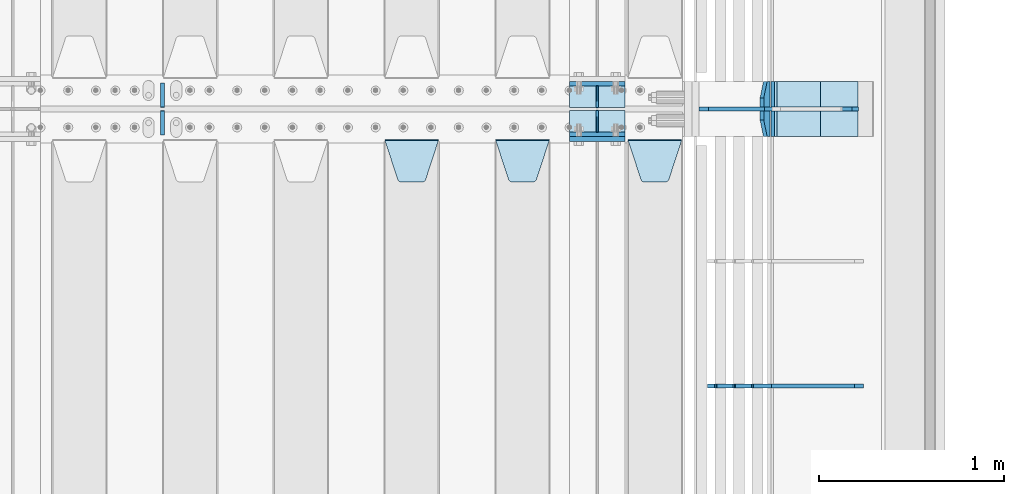
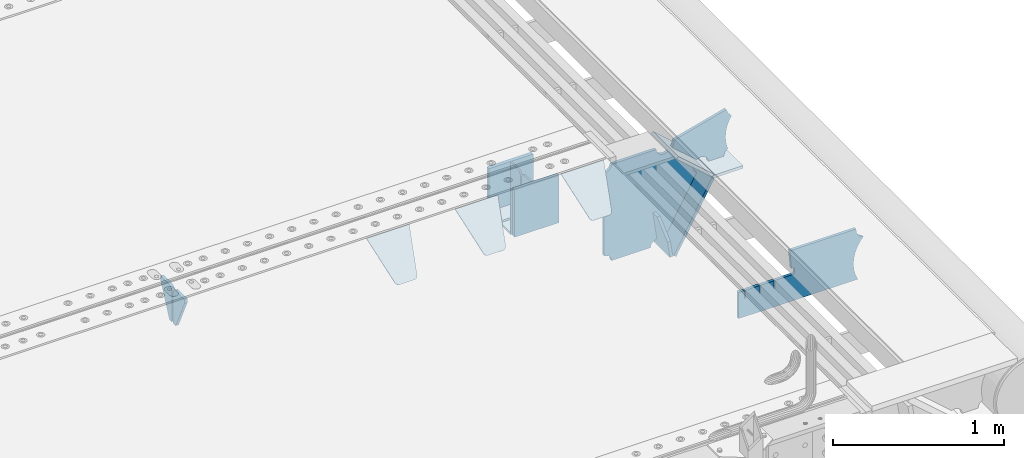
# One storey, part 186 of 219: 19 plates.
"""IFC2X3 building model written with IfcOpenShell, lengths in millimetres."""

from ifc_helpers import new_model, si_unit, frame, origin_with_axes, place, context, subcontext, project, spatial, faceted_brep, material, type_object, element, save


model = new_model("IFC2X3")

# Units and contexts
model_context = context("Model", 3, precision=1e-05, world=origin_with_axes())
body_context = subcontext(model_context, "Body", "Model", "MODEL_VIEW")
ifc_project = project(units=[si_unit("LENGTHUNIT", "METRE", prefix="MILLI"), si_unit("AREAUNIT", "SQUARE_METRE"), si_unit("VOLUMEUNIT", "CUBIC_METRE"), si_unit("MASSUNIT", "GRAM", prefix="KILO"), si_unit("TIMEUNIT", "SECOND"), si_unit("PLANEANGLEUNIT", "RADIAN"), si_unit("SOLIDANGLEUNIT", "STERADIAN"), si_unit("THERMODYNAMICTEMPERATUREUNIT", "DEGREE_CELSIUS"), si_unit("LUMINOUSINTENSITYUNIT", "LUMEN")], contexts=[model_context])

# Site, building, storey
site_placement = place(None, origin_with_axes())
site = spatial("IfcSite", under=ifc_project, at=site_placement, CompositionType="ELEMENT")
building_placement = place(site_placement, origin_with_axes())
building = spatial("IfcBuilding", under=site, at=building_placement, Name="Standard", CompositionType="ELEMENT")
storey_placement = place(building_placement, origin_with_axes())
storey = spatial("IfcBuildingStorey", under=building, at=storey_placement, Name="Undefined", CompositionType="ELEMENT", Elevation=0.0)

# Plates
ifc_material = material(Name="STEEL/S355N")
plate_type_1 = type_object("IfcPlateType", PredefinedType="NOTDEFINED")
for number, where, z_axis, x_axis in (
    (1, (13405.0, 27137.5, -339.999999999995), (0.0, 0.0, 1.0), (1.0, 0.0, 0.0)),
    (2, (13405.0, 26862.5, -339.999999999995), (0.0, 0.0, 1.0), (1.0, 0.0, 0.0)),
):
    element("IfcPlate", number, at=place(storey_placement, frame(where, z_axis=z_axis, x_axis=x_axis)), inside=storey, type_object=plate_type_1, material=ifc_material, context=body_context, shape_type="Brep", body=[
        faceted_brep([(0.0, -12.5, 0.0), (0.0, -12.5, 310.0), (0.0, 12.5, 310.0), (0.0, 12.5, 0.0), (300.0, -12.5, 310.0), (300.0, 12.5, 310.0), (300.0, -12.5, 0.0), (300.0, 12.5, 0.0)], [[[0, 1, 2, 3]], [[1, 4, 5, 2]], [[4, 6, 7, 5]], [[6, 0, 3, 7]], [[5, 7, 3, 2]], [[6, 4, 1, 0]]]),
    ])
plate_1_placement = place(storey_placement, frame((13405.0, 26837.5, -340.000000000044), z_axis=(0.0, 0.0, 1.0), x_axis=(1.0, 0.0, 0.0)))
element("IfcPlate", 3, at=plate_1_placement, inside=storey, type_object=plate_type_1, material=ifc_material, context=body_context, shape_type="Brep", body=[
    faceted_brep([(0.0, -12.5, 0.0), (9.27684595808387e-10, -12.5, 340.0), (9.27684595808387e-10, 12.5, 340.0), (0.0, 12.5, 0.0), (300.0, -12.5, 340.0), (300.0, 12.5, 340.0), (300.0, -12.5, 0.0), (300.0, 12.5, 0.0)], [[[0, 1, 2, 3]], [[1, 4, 5, 2]], [[4, 6, 7, 5]], [[6, 0, 3, 7]], [[5, 7, 3, 2]], [[6, 4, 1, 0]]]),
])
plate_type_2 = type_object("IfcPlateType", PredefinedType="NOTDEFINED")
for number, where, z_axis, x_axis in (
    (4, (13405.0, 27008.0, -342.999999999995), (0.0, 1.0, 0.0), (1.0, 0.0, 0.0)),
    (5, (13405.0, 26992.0, -342.999999999995), (0.0, -1.0, 0.0), (1.0, 0.0, 0.0)),
):
    element("IfcPlate", number, at=place(storey_placement, frame(where, z_axis=z_axis, x_axis=x_axis)), inside=storey, type_object=plate_type_2, material=ifc_material, context=body_context, shape_type="Brep", body=[
        faceted_brep([(0.0, -7.0, 0.0), (0.0, -7.0, 117.0), (0.0, 7.0, 117.0), (0.0, 7.0, 0.0), (300.0, -7.0, 117.0), (300.0, 7.0, 117.0), (300.0, -7.0, 0.0), (300.0, 7.0, 0.0)], [[[0, 1, 2, 3]], [[1, 4, 5, 2]], [[4, 6, 7, 5]], [[6, 0, 3, 7]], [[5, 7, 3, 2]], [[6, 4, 1, 0]]]),
    ])
plate_type_3 = type_object("IfcPlateType", PredefinedType="NOTDEFINED")
for number, where, z_axis, x_axis in (
    (6, (13555.0, 27008.0, -29.9999999999945), (0.0, 0.0, -1.0), (0.0, 1.0, 0.0)),
    (7, (13555.0, 26992.0, -29.9999999999945), (0.0, 0.0, -1.0), (0.0, -1.0, 0.0)),
):
    element("IfcPlate", number, at=place(storey_placement, frame(where, z_axis=z_axis, x_axis=x_axis)), inside=storey, type_object=plate_type_3, material=ifc_material, context=body_context, shape_type="Brep", body=[
        faceted_brep([(0.0, -5.0, 30.0), (0.0, -5.0, 306.0), (0.0, 5.0, 306.0), (0.0, 5.0, 30.0), (117.0, -5.0, 306.0), (117.0, 5.0, 306.0), (117.0, -5.0, 0.0), (117.0, 5.0, 0.0), (30.0, -5.0, 0.0), (30.0, 5.0, 0.0), (24.7905546699913, -5.0, 0.455767409633758), (24.7905546699913, 5.0, 0.455767409633758), (19.7393957002278, -5.0, 1.80922137642275), (19.7393957002278, 5.0, 1.80922137642275), (15.0, -5.0, 4.01923788646684), (15.0, 5.0, 4.01923788646684), (10.7163717094008, -5.0, 7.01866670643066), (10.7163717094008, 5.0, 7.01866670643066), (7.01866670643358, -5.0, 10.7163717094038), (7.01866670643358, 5.0, 10.7163717094038), (4.01923788646673, -5.0, 15.0), (4.01923788646673, 5.0, 15.0), (1.80922137642483, -5.0, 19.7393957002299), (1.80922137642483, 5.0, 19.7393957002299), (0.455767409635882, -5.0, 24.7905546699921), (0.455767409635882, 5.0, 24.7905546699921)], [[[0, 1, 2, 3]], [[1, 4, 5, 2]], [[4, 6, 7, 5]], [[6, 8, 9, 7]], [[8, 10, 11, 9]], [[10, 12, 13, 11]], [[12, 14, 15, 13]], [[14, 16, 17, 15]], [[16, 18, 19, 17]], [[18, 20, 21, 19]], [[20, 22, 23, 21]], [[22, 24, 25, 23]], [[24, 0, 3, 25]], [[5, 7, 9, 11, 13, 15, 17, 19, 21, 23, 25, 3, 2]], [[24, 22, 20, 18, 16, 14, 12, 10, 8, 6, 4, 1, 0]]]),
    ])
plate_type_4 = type_object("IfcPlateType", PredefinedType="NOTDEFINED")
plate_2_placement = place(storey_placement, frame((13722.0, 26831.767766956, -1.76776695296758), z_axis=(0.0, -0.707106781186547, -0.707106781186548), x_axis=(1.0, 0.0, 0.0)))
element("IfcPlate", 8, at=plate_2_placement, inside=storey, type_object=plate_type_4, material=ifc_material, context=body_context, shape_type="Brep", body=[
    faceted_brep([(0.0, -2.5, 0.0), (69.345504679477, -2.5, 300.171731424834), (69.345504679477, 2.49999999999636, 300.171731424831), (0.0, 2.5, 0.0), (70.9274061199576, -2.50000000000364, 304.8974424154), (70.9274061199576, 2.49999999999636, 304.8974424154), (73.3818627772307, -2.50000000000364, 309.234538108532), (73.3818627772307, 2.49999999999636, 309.234538108532), (76.6187032999569, -2.50000000000364, 313.023683126106), (76.6187032999569, 2.49999999999636, 313.023683126106), (80.5190132704993, -2.50000000000364, 316.125672595372), (80.5190132704993, 2.49999999999636, 316.125672595372), (84.9395038596831, -2.50000000000364, 318.426546230476), (84.9395038596831, 2.5, 318.426546230479), (89.7177759439237, -2.50000000000364, 319.841774983277), (89.7177759439237, 2.5, 319.841774983281), (94.6782862926502, -2.50000000000364, 320.319366455078), (94.6782862926502, 2.49999999999636, 320.319366455078), (195.32171370735, -2.50000000000364, 320.319366455078), (195.32171370735, 2.49999999999636, 320.319366455078), (200.282224056076, -2.50000000000364, 319.841774983277), (200.282224056076, 2.5, 319.841774983281), (205.060496140317, -2.50000000000364, 318.426546230476), (205.060496140317, 2.49999999999636, 318.426546230476), (209.480986729501, -2.50000000000364, 316.125672595372), (209.480986729501, 2.49999999999636, 316.125672595372), (213.381296700043, -2.50000000000364, 313.023683126106), (213.381296700043, 2.49999999999272, 313.023683126106), (216.618137222769, -2.50000000000364, 309.234538108529), (216.618137222769, 2.49999999999636, 309.234538108525), (219.072593880042, -2.50000000000364, 304.8974424154), (219.072593880042, 2.49999999999636, 304.8974424154), (220.654495320523, -2.5, 300.171731424834), (220.654495320523, 2.49999999999636, 300.171731424831), (290.0, -2.50000000000364, 3.63797880709171e-12), (290.0, 2.49999999999636, 0.0)], [[[0, 1, 2, 3]], [[1, 4, 5, 2]], [[4, 6, 7, 5]], [[6, 8, 9, 7]], [[8, 10, 11, 9]], [[10, 12, 13, 11]], [[12, 14, 15, 13]], [[14, 16, 17, 15]], [[16, 18, 19, 17]], [[18, 20, 21, 19]], [[20, 22, 23, 21]], [[22, 24, 25, 23]], [[24, 26, 27, 25]], [[26, 28, 29, 27]], [[28, 30, 31, 29]], [[30, 32, 33, 31]], [[32, 34, 35, 33]], [[34, 0, 3, 35]], [[5, 7, 9, 11, 13, 15, 17, 19, 21, 23, 25, 27, 29, 31, 33, 35, 3, 2]], [[34, 32, 30, 28, 26, 24, 22, 20, 18, 16, 14, 12, 10, 8, 6, 4, 1, 0]]]),
])
plate_3_placement = place(storey_placement, frame((13005.0, 26831.767766956, -1.76776695296758), z_axis=(0.0, -0.707106781186547, -0.707106781186548), x_axis=(1.0, 0.0, 0.0)))
element("IfcPlate", 9, at=plate_3_placement, inside=storey, type_object=plate_type_4, material=ifc_material, context=body_context, shape_type="Brep", body=[
    faceted_brep([(0.0, -2.5, 0.0), (69.345504679477, -2.5, 300.171731424834), (69.345504679477, 2.49999999999636, 300.171731424831), (0.0, 2.5, 0.0), (70.9274061199576, -2.50000000000364, 304.8974424154), (70.9274061199576, 2.49999999999636, 304.8974424154), (73.3818627772307, -2.50000000000364, 309.234538108532), (73.3818627772307, 2.49999999999636, 309.234538108532), (76.6187032999569, -2.50000000000364, 313.023683126106), (76.6187032999569, 2.49999999999636, 313.023683126106), (80.5190132704993, -2.50000000000364, 316.125672595372), (80.5190132704993, 2.49999999999636, 316.125672595372), (84.9395038596831, -2.50000000000364, 318.426546230476), (84.9395038596831, 2.5, 318.426546230479), (89.7177759439237, -2.50000000000364, 319.841774983277), (89.7177759439237, 2.5, 319.841774983281), (94.6782862926502, -2.50000000000364, 320.319366455078), (94.6782862926502, 2.49999999999636, 320.319366455078), (195.32171370735, -2.50000000000364, 320.319366455078), (195.32171370735, 2.49999999999636, 320.319366455078), (200.282224056076, -2.50000000000364, 319.841774983277), (200.282224056076, 2.5, 319.841774983281), (205.060496140317, -2.50000000000364, 318.426546230476), (205.060496140317, 2.49999999999636, 318.426546230476), (209.480986729501, -2.50000000000364, 316.125672595372), (209.480986729501, 2.49999999999636, 316.125672595372), (213.381296700043, -2.50000000000364, 313.023683126106), (213.381296700043, 2.49999999999272, 313.023683126106), (216.618137222769, -2.50000000000364, 309.234538108529), (216.618137222769, 2.49999999999636, 309.234538108525), (219.072593880042, -2.50000000000364, 304.8974424154), (219.072593880042, 2.49999999999636, 304.8974424154), (220.654495320523, -2.5, 300.171731424834), (220.654495320523, 2.49999999999636, 300.171731424831), (290.0, -2.50000000000364, 3.63797880709171e-12), (290.0, 2.49999999999636, 0.0)], [[[0, 1, 2, 3]], [[1, 4, 5, 2]], [[4, 6, 7, 5]], [[6, 8, 9, 7]], [[8, 10, 11, 9]], [[10, 12, 13, 11]], [[12, 14, 15, 13]], [[14, 16, 17, 15]], [[16, 18, 19, 17]], [[18, 20, 21, 19]], [[20, 22, 23, 21]], [[22, 24, 25, 23]], [[24, 26, 27, 25]], [[26, 28, 29, 27]], [[28, 30, 31, 29]], [[30, 32, 33, 31]], [[32, 34, 35, 33]], [[34, 0, 3, 35]], [[5, 7, 9, 11, 13, 15, 17, 19, 21, 23, 25, 27, 29, 31, 33, 35, 3, 2]], [[34, 32, 30, 28, 26, 24, 22, 20, 18, 16, 14, 12, 10, 8, 6, 4, 1, 0]]]),
])
plate_4_placement = place(storey_placement, frame((12405.0, 26831.767766956, -1.76776695296758), z_axis=(0.0, -0.707106781186547, -0.707106781186548), x_axis=(1.0, 0.0, 0.0)))
element("IfcPlate", 10, at=plate_4_placement, inside=storey, type_object=plate_type_4, material=ifc_material, context=body_context, shape_type="Brep", body=[
    faceted_brep([(0.0, -2.5, 0.0), (69.345504679477, -2.5, 300.171731424834), (69.345504679477, 2.49999999999636, 300.171731424831), (0.0, 2.5, 0.0), (70.9274061199576, -2.50000000000364, 304.8974424154), (70.9274061199576, 2.49999999999636, 304.8974424154), (73.3818627772307, -2.50000000000364, 309.234538108532), (73.3818627772307, 2.49999999999636, 309.234538108532), (76.6187032999569, -2.50000000000364, 313.023683126106), (76.6187032999569, 2.49999999999636, 313.023683126106), (80.5190132704993, -2.50000000000364, 316.125672595372), (80.5190132704993, 2.49999999999636, 316.125672595372), (84.9395038596831, -2.50000000000364, 318.426546230476), (84.9395038596831, 2.5, 318.426546230479), (89.7177759439237, -2.50000000000364, 319.841774983277), (89.7177759439237, 2.5, 319.841774983281), (94.6782862926502, -2.50000000000364, 320.319366455078), (94.6782862926502, 2.49999999999636, 320.319366455078), (195.32171370735, -2.50000000000364, 320.319366455078), (195.32171370735, 2.49999999999636, 320.319366455078), (200.282224056076, -2.50000000000364, 319.841774983277), (200.282224056076, 2.5, 319.841774983281), (205.060496140317, -2.50000000000364, 318.426546230476), (205.060496140317, 2.49999999999636, 318.426546230476), (209.480986729501, -2.50000000000364, 316.125672595372), (209.480986729501, 2.49999999999636, 316.125672595372), (213.381296700043, -2.50000000000364, 313.023683126106), (213.381296700043, 2.49999999999272, 313.023683126106), (216.618137222769, -2.50000000000364, 309.234538108529), (216.618137222769, 2.49999999999636, 309.234538108525), (219.072593880042, -2.50000000000364, 304.8974424154), (219.072593880042, 2.49999999999636, 304.8974424154), (220.654495320523, -2.5, 300.171731424834), (220.654495320523, 2.49999999999636, 300.171731424831), (290.0, -2.50000000000364, 3.63797880709171e-12), (290.0, 2.49999999999636, 0.0)], [[[0, 1, 2, 3]], [[1, 4, 5, 2]], [[4, 6, 7, 5]], [[6, 8, 9, 7]], [[8, 10, 11, 9]], [[10, 12, 13, 11]], [[12, 14, 15, 13]], [[14, 16, 17, 15]], [[16, 18, 19, 17]], [[18, 20, 21, 19]], [[20, 22, 23, 21]], [[22, 24, 25, 23]], [[24, 26, 27, 25]], [[26, 28, 29, 27]], [[28, 30, 31, 29]], [[30, 32, 33, 31]], [[32, 34, 35, 33]], [[34, 0, 3, 35]], [[5, 7, 9, 11, 13, 15, 17, 19, 21, 23, 25, 27, 29, 31, 33, 35, 3, 2]], [[34, 32, 30, 28, 26, 24, 22, 20, 18, 16, 14, 12, 10, 8, 6, 4, 1, 0]]]),
])
plate_type_5 = type_object("IfcPlateType", PredefinedType="NOTDEFINED")
plate_5_placement = place(storey_placement, frame((14481.0775331947, 27150.0000000017, -871.412303810021), z_axis=(0.0, -1.0, 0.0), x_axis=(-0.137902988002462, 0.0, 0.990445741017645)))
element("IfcPlate", 11, at=plate_5_placement, inside=storey, type_object=plate_type_5, material=ifc_material, context=body_context, shape_type="Brep", body=[
    faceted_brep([(0.0, -10.0, 0.0), (-1.97815097635612e-10, -10.0, 300.0), (-1.97815097635612e-10, 10.0000000000018, 300.0), (0.0, 10.0, 0.0), (115.0, -10.0, 300.0), (115.0, 10.0, 300.0), (250.0, -10.0, 210.0), (250.0, 10.0, 210.0), (250.0, -10.0, 90.0), (250.0, 10.0, 90.0), (115.0, -10.0, -1.09139364212751e-10), (115.0, 10.0, -1.09139364212751e-10)], [[[0, 1, 2, 3]], [[1, 4, 5, 2]], [[4, 6, 7, 5]], [[6, 8, 9, 7]], [[8, 10, 11, 9]], [[10, 0, 3, 11]], [[5, 7, 9, 11, 3, 2]], [[10, 8, 6, 4, 1, 0]]]),
])
plate_type_6 = type_object("IfcPlateType", PredefinedType="NOTDEFINED")
plate_6_placement = place(storey_placement, frame((14509.9988298914, 27000.0000000001, -179.999999999866), z_axis=(0.0, 0.0, -1.0), x_axis=(-1.0, 0.0, 0.0)))
element("IfcPlate", 12, at=plate_6_placement, inside=storey, type_object=plate_type_6, material=ifc_material, context=body_context, shape_type="Brep", body=[
    faceted_brep([(46.0258547361573, 10.0, 641.078828352488), (73.3015011074949, 10.0000000000109, 445.179898435785), (73.3015011074949, -9.99999999998545, 445.179898435785), (46.0258547361573, -10.0, 641.078828352488), (53.4925862871423, 10.0000000000109, 442.421838675736), (53.4925862871423, -9.99999999998545, 442.421838675736), (25.7820501124042, 10.0, 641.444230671291), (25.7820501124042, -10.0, 641.444230671291), (54.66525031116, 10.0, 642.447174185377), (54.66525031116, -10.0, 642.447174185377), (68.6036632070372, -10.0, 649.549150281387), (68.6036632070372, 10.0, 649.549150281387), (79.66525031116, -10.0, 660.610737385511), (79.66525031116, 10.0, 660.610737385511), (86.7672264071698, -10.0, 674.549150281387), (86.7672264071698, 10.0, 674.549150281387), (89.2144005924129, -10.0, 690.0), (89.2144005924129, 10.0, 690.0), (353.0, -10.0, 690.0), (353.0, 10.0, 690.0), (355.447174185243, -10.0, 674.549150281253), (355.447174185243, 10.0, 674.549150281253), (362.549150281253, -10.0, 660.610737385376), (362.549150281253, 10.0, 660.610737385376), (373.610737385376, -10.0, 649.549150281253), (373.610737385376, 10.0, 649.549150281253), (387.549150281253, -10.0, 642.447174185242), (387.549150281253, 10.0, 642.447174185242), (403.0, -10.0, 640.0), (403.0, 10.0, 640.0), (403.0, -10.0, 50.0), (403.0, 10.0, 50.0), (387.549150281253, -10.0, 47.5528258147577), (387.549150281253, 10.0, 47.5528258147577), (373.610737385376, -10.0, 40.4508497187474), (373.610737385376, 10.0, 40.4508497187474), (362.549150281253, -10.0, 29.3892626146236), (362.549150281253, 10.0, 29.3892626146236), (355.447174185243, -10.0, 15.4508497187474), (355.447174185243, 10.0, 15.4508497187474), (353.0, -10.0, 0.0), (353.0, 10.0, 0.0), (50.0, -10.0, 0.0), (50.0, 10.0, 0.0), (47.0349915316328, -10.0, 16.9620037619133), (47.0349915316328, 10.0, 16.9620037619133), (38.4916171352343, -10.0, 31.9123081320451), (38.4916171352343, 10.0, 31.9123081320451), (25.3831239081501, -10.0, 43.0778019479116), (25.3831239081501, 10.0, 43.0778019479116), (9.26418358741648, -10.0, 49.1342538608113), (9.26418358741648, 10.0, 49.1342538608113), (-7.95349204488593, -10.0, 49.363366622344), (-7.95349204488593, 10.0, 49.363366622344), (-24.2278808265401, -10.0, 43.7379673813837), (-24.2278808265401, 10.0, 43.7379673813837), (-37.6288347353438, -10.0, 32.9252303934259), (-37.6288347353438, 10.0, 32.9252303934259), (-210.371165264656, -10.0, 184.074769606574), (-210.371165264656, 10.0, 184.074769606574), (-202.382363280569, -10.0, 196.529747922069), (-202.382363280569, 10.0, 196.529747922069), (-198.388707244047, -10.0, 210.777489969227), (-198.388707244047, 10.0, 210.777489969227), (-198.739957464426, -10.0, 225.570193077959), (-198.739957464426, 10.0, 225.570193077959), (-203.40535180681, -10.0, 239.612327446012), (-203.40535180681, 10.0, 239.612327446012), (-211.976299808361, -10.0, 251.674097313455), (-211.976299808361, 10.0, 251.674097313455), (-223.702166612962, -10.0, 260.699145216992), (-223.702166612962, 10.0, 260.699145216992), (-9.29783338703783, -10.0, 646.300854783008), (-9.29783338703783, 10.0, 646.300854783008), (6.98069453597964, -10.0, 640.647282345602), (6.98069453597964, 10.0, 640.647282345602), (24.2117663163681, -10.0, 640.855891896051), (24.2117663163681, 10.0, 640.855891896051)], [[[0, 1, 2, 3]], [[4, 5, 2, 1]], [[6, 7, 5, 4]], [[8, 9, 10, 11]], [[11, 10, 12, 13]], [[13, 12, 14, 15]], [[15, 14, 16, 17]], [[18, 19, 17, 16]], [[18, 20, 21, 19]], [[20, 22, 23, 21]], [[22, 24, 25, 23]], [[24, 26, 27, 25]], [[26, 28, 29, 27]], [[28, 30, 31, 29]], [[30, 32, 33, 31]], [[32, 34, 35, 33]], [[34, 36, 37, 35]], [[36, 38, 39, 37]], [[38, 40, 41, 39]], [[40, 42, 43, 41]], [[42, 44, 45, 43]], [[44, 46, 47, 45]], [[46, 48, 49, 47]], [[48, 50, 51, 49]], [[50, 52, 53, 51]], [[52, 54, 55, 53]], [[54, 56, 57, 55]], [[56, 58, 59, 57]], [[58, 60, 61, 59]], [[60, 62, 63, 61]], [[62, 64, 65, 63]], [[64, 66, 67, 65]], [[66, 68, 69, 67]], [[68, 70, 71, 69]], [[70, 72, 73, 71]], [[72, 74, 75, 73]], [[74, 76, 77, 75]], [[1, 0, 8, 11, 13, 15, 17, 19, 21, 23, 25, 27, 29, 31, 33, 35, 37, 39, 41, 43, 45, 47, 49, 51, 53, 55, 57, 59, 61, 63, 65, 67, 69, 71, 73, 75, 77, 6, 4]], [[9, 8, 0, 3]], [[76, 74, 72, 70, 68, 66, 64, 62, 60, 58, 56, 54, 52, 50, 48, 46, 44, 42, 40, 38, 36, 34, 32, 30, 28, 26, 24, 22, 20, 18, 16, 14, 12, 10, 9, 3, 2, 5, 7]], [[77, 76, 7, 6]]]),
])
plate_type_7 = type_object("IfcPlateType", PredefinedType="NOTDEFINED")
plate_7_placement = place(storey_placement, frame((15050.9988502513, 26999.9999999993, -28.9999913318487), z_axis=(0.260769276985653, 0.0, -0.965401151946889), x_axis=(-0.965401151946889, 0.0, -0.260769276985654)))
element("IfcPlate", 13, at=plate_7_placement, inside=storey, type_object=plate_type_7, material=ifc_material, context=body_context, shape_type="Brep", body=[
    faceted_brep([(183.436474692322, 10.0, 275.852500330424), (184.918388609056, 10.0, 264.417843531324), (184.918388609056, -10.0, 264.417843531324), (183.436474692322, -10.0, 275.852500330424), (183.794583267612, 10.0, 224.576469334609), (183.794583267612, -10.0, 224.576469334609), (176.452049775835, 10.0, 185.401410454623), (176.452049775835, -10.0, 185.401410454623), (163.071585676769, 10.0, 147.857286855559), (163.071585676769, -10.0, 147.857286855559), (143.982662403743, 10.0, 112.868559462228), (143.982662403743, -10.0, 112.868559462228), (119.655312600249, 10.0, 81.2967668639835), (119.655312600249, -10.0, 81.2967668639835), (100.960891712748, 10.0, 63.6280409830915), (100.960891712748, -10.0, 63.6280409830915), (194.486836975902, -10.0, 278.751956446687), (207.178624553371, -10.0, 286.650994937515), (207.178624553371, 10.0, 286.650994937515), (194.486836975902, 10.0, 278.751956446687), (216.968013469443, -10.0, 297.948965801396), (216.968013469443, 10.0, 297.948965801396), (222.979925232859, -10.0, 311.635937633766), (222.979925232859, 10.0, 311.635937633766), (323.381647032762, -10.0, 284.515917834984), (323.381647032762, 10.0, 284.515917834984), (321.720617177332, -10.0, 268.853198956861), (321.720617177332, 10.0, 268.853198956861), (325.01434448114, -10.0, 253.450889283182), (325.01434448114, 10.0, 253.450889283182), (332.935986082481, -10.0, 239.837389469555), (332.935986082481, 10.0, 239.837389469555), (344.699462330087, -10.0, 229.363593146937), (344.699462330087, 10.0, 229.363593146937), (359.137460970805, -10.0, 223.068835162201), (359.137460970805, 10.0, 223.068835162201), (374.817271777683, -10.0, 221.57775639289), (374.817271777683, 10.0, 221.57775639289), (390.182952880858, -10.0, 225.038330078125), (390.182952880858, 10.0, 225.038330078125), (512.909060513028, -10.0, 41.5599003357015), (512.909060513028, 10.0, 41.5599003357015), (503.648024844581, -10.0, 33.5643666747674), (503.648024844581, 10.0, 33.5643666747674), (496.606064569702, -10.0, 23.5590612989986), (496.606064569702, 10.0, 23.5590612989986), (492.204839143929, -10.0, 12.1430832451083), (492.204839143929, 10.0, 12.1430832451083), (490.707885742186, -10.0, 3.79714037990198e-10), (490.707885742186, 10.0, 3.79714037990198e-10), (119.999999999998, -10.0, 9.27684595808387e-11), (119.999999999998, 10.0, 9.27684595808387e-11), (117.226254779109, -10.0, 25.651611849215), (117.226254779109, 10.0, 25.651611849215), (109.033246825658, -10.0, 50.1173731020972), (109.033246825658, 10.0, 50.1173731020972)], [[[0, 1, 2, 3]], [[4, 5, 2, 1]], [[6, 7, 5, 4]], [[8, 9, 7, 6]], [[10, 11, 9, 8]], [[12, 13, 11, 10]], [[14, 15, 13, 12]], [[16, 17, 18, 19]], [[17, 20, 21, 18]], [[20, 22, 23, 21]], [[22, 24, 25, 23]], [[24, 26, 27, 25]], [[26, 28, 29, 27]], [[28, 30, 31, 29]], [[30, 32, 33, 31]], [[32, 34, 35, 33]], [[34, 36, 37, 35]], [[36, 38, 39, 37]], [[38, 40, 41, 39]], [[40, 42, 43, 41]], [[42, 44, 45, 43]], [[44, 46, 47, 45]], [[46, 48, 49, 47]], [[48, 50, 51, 49]], [[50, 52, 53, 51]], [[52, 54, 55, 53]], [[10, 8, 6, 4, 1, 0, 19, 18, 21, 23, 25, 27, 29, 31, 33, 35, 37, 39, 41, 43, 45, 47, 49, 51, 53, 55, 14, 12]], [[16, 19, 0, 3]], [[54, 52, 50, 48, 46, 44, 42, 40, 38, 36, 34, 32, 30, 28, 26, 24, 22, 20, 17, 16, 3, 2, 5, 7, 9, 11, 13, 15]], [[55, 54, 15, 14]]]),
])
plate_type_8 = type_object("IfcPlateType", PredefinedType="NOTDEFINED")
plate_8_placement = place(storey_placement, frame((14522.2260590443, 27149.9999999993, -177.219372761326), z_axis=(0.752414935148685, 0.0, -0.658689430130164), x_axis=(0.0, -1.0, 0.0)))
element("IfcPlate", 14, at=plate_8_placement, inside=storey, type_object=plate_type_8, material=ifc_material, context=body_context, shape_type="Brep", body=[
    faceted_brep([(0.0, -10.0, 0.0), (1.09139364212751e-10, -10.0000000000018, 319.999999999998), (1.09139364212751e-10, 10.0, 319.999999999998), (0.0, 10.0, 0.0), (300.0, -10.0000000000018, 319.999999999998), (300.0, 10.0, 319.999999999998), (300.0, -10.0, 6.73026079311967e-11), (300.0, 10.0, 6.73026079311967e-11)], [[[0, 1, 2, 3]], [[1, 4, 5, 2]], [[4, 6, 7, 5]], [[6, 0, 3, 7]], [[5, 7, 3, 2]], [[6, 4, 1, 0]]]),
])
plate_9_placement = place(storey_placement, frame((14763.0007288109, 27150.0000000001, -408.004820491625), z_axis=(-0.484064236150486, 0.0, -0.87503246527203), x_axis=(0.0, -1.0, 0.0)))
element("IfcPlate", 15, at=plate_9_placement, inside=storey, type_object=plate_type_8, material=ifc_material, context=body_context, shape_type="Brep", body=[
    faceted_brep([(0.0, -10.0, 0.0), (3.86513420380652e-07, -10.0, 533.528442382813), (3.86513420380652e-07, 9.99999999999818, 533.528442382814), (0.0, 10.0, 0.0), (300.003295898438, -10.0, 533.549133300783), (300.003295898438, 9.99999999999818, 533.549133300783), (300.0, -10.0, 6.73026079311967e-11), (300.0, 10.0, 6.73026079311967e-11)], [[[0, 1, 2, 3]], [[1, 4, 5, 2]], [[4, 6, 7, 5]], [[6, 0, 3, 7]], [[5, 7, 3, 2]], [[6, 4, 1, 0]]]),
])
plate_type_9 = type_object("IfcPlateType", PredefinedType="NOTDEFINED")
plate_10_placement = place(storey_placement, frame((14966.9988298914, 27149.9999999993, -397.999999999763), z_axis=(-1.0, 0.0, 0.0), x_axis=(0.0, -1.0, 0.0)))
element("IfcPlate", 16, at=plate_10_placement, inside=storey, type_object=plate_type_9, material=ifc_material, context=body_context, shape_type="Brep", body=[
    faceted_brep([(0.0, -10.0, 0.0), (4.65661287307739e-10, -10.0, 204.0), (4.65661287307739e-10, 10.0, 204.0), (0.0, 10.0, 0.0), (300.0, -10.0, 204.0), (300.0, 10.0, 204.0), (300.0, -10.0, 6.73026079311967e-11), (300.0, 10.0, 6.73026079311967e-11)], [[[0, 1, 2, 3]], [[1, 4, 5, 2]], [[4, 6, 7, 5]], [[6, 0, 3, 7]], [[5, 7, 3, 2]], [[6, 4, 1, 0]]]),
])
plate_type_10 = type_object("IfcPlateType", PredefinedType="NOTDEFINED")
for number, where, z_axis, x_axis in (
    (17, (11200.0, 27140.0, -30.0), (0.0, 0.0, -1.0), (0.0, -1.0, 0.0)),
    (18, (11200.0, 26860.0, -30.0), (0.0, 0.0, -1.0), (0.0, 1.0, 0.0)),
):
    element("IfcPlate", number, at=place(storey_placement, frame(where, z_axis=z_axis, x_axis=x_axis)), inside=storey, type_object=plate_type_10, material=ifc_material, context=body_context, shape_type="Brep", body=[
        faceted_brep([(0.0, -10.0, 0.0), (0.0, -10.0, 30.0), (0.0, 10.0, 30.0), (0.0, 10.0, 0.0), (102.0, -10.0, 250.0), (102.0, 10.0, 250.0), (132.0, -10.0, 250.0), (132.0, 10.0, 250.0), (132.0, -10.0, 30.0), (132.0, 10.0, 30.0), (131.544232590368, -10.0, 24.790554669992), (131.544232590368, 10.0, 24.790554669992), (130.190778623579, -10.0, 19.7393957002299), (130.190778623579, 10.0, 19.7393957002299), (127.980762113533, -10.0, 15.0), (127.980762113533, 10.0, 15.0), (124.98133329357, -10.0, 10.7163717094038), (124.98133329357, 10.0, 10.7163717094038), (121.283628290596, -10.0, 7.01866670643062), (121.283628290596, 10.0, 7.01866670643062), (117.0, -10.0, 4.01923788646684), (117.0, 10.0, 4.01923788646684), (112.260604299769, -10.0, 1.80922137642278), (112.260604299769, 10.0, 1.80922137642278), (107.209445330009, -10.0, 0.455767409633722), (107.209445330009, 10.0, 0.455767409633722), (102.0, -10.0, 0.0), (102.0, 10.0, 0.0)], [[[0, 1, 2, 3]], [[1, 4, 5, 2]], [[4, 6, 7, 5]], [[6, 8, 9, 7]], [[8, 10, 11, 9]], [[10, 12, 13, 11]], [[12, 14, 15, 13]], [[14, 16, 17, 15]], [[16, 18, 19, 17]], [[18, 20, 21, 19]], [[20, 22, 23, 21]], [[22, 24, 25, 23]], [[24, 26, 27, 25]], [[26, 0, 3, 27]], [[5, 7, 9, 11, 13, 15, 17, 19, 21, 23, 25, 27, 3, 2]], [[26, 24, 22, 20, 18, 16, 14, 12, 10, 8, 6, 4, 1, 0]]]),
    ])
plate_type_11 = type_object("IfcPlateType", PredefinedType="NOTDEFINED")
plate_11_placement = place(storey_placement, frame((14992.9182339676, 25499.9992828369, -374.002067436517), z_axis=(0.0, 0.0, 1.0), x_axis=(-1.0, 0.0, 0.0)))
element("IfcPlate", 19, at=plate_11_placement, inside=storey, type_object=plate_type_11, material=ifc_material, context=body_context, shape_type="Brep", body=[
    faceted_brep([(801.919404066546, -10.0, 188.0), (801.919404066546, 10.0, 188.0), (801.919404066546, 10.0, 132.002067436952), (801.919404066546, -9.99999999999636, 132.002067436952), (793.919404066546, 10.0, 132.002067436952), (793.919404066546, -9.99999999999636, 132.002067436952), (793.919404066546, 10.0, 180.002067436952), (793.919404066546, -10.0, 180.002067436952), (793.527856196908, 10.0, 182.474203391951), (793.527856196908, -10.0, 182.474203391951), (792.391540021546, 10.0, 184.704349455291), (792.391540021546, -10.0, 184.704349455291), (790.621686084885, 10.0, 186.474203391951), (790.621686084885, -10.0, 186.474203391951), (788.391540021546, 10.0, 187.610519567313), (788.391540021546, -10.0, 187.610519567313), (785.919404066546, -10.0, 188.002067436952), (785.919404066546, 10.0, 188.0), (841.0, -10.0, 188.0), (841.0, -10.0, 0.0), (841.0, 10.0, 0.0), (841.0, 10.0, 188.0), (33.3619566736033, -10.0, 0.0), (33.3619566736033, 10.0, 0.0), (36.2350612208174, -10.0, 4.68848050267013), (36.2350612208174, 10.0, 4.68848050267013), (51.487759215941, -10.0, 41.5117508652784), (51.487759215941, 10.0, 41.5117508652784), (60.792242588137, -10.0, 80.2677133162964), (60.792242588137, 10.0, 80.2677133162964), (63.9194040769726, -10.0, 120.002067436515), (63.9194040769726, 10.0, 120.002067436515), (60.792242588137, -10.0, 159.736421556734), (60.792242588137, 10.0, 159.736421556734), (51.487759215941, -10.0, 198.492384007752), (51.487759215941, 10.0, 198.492384007752), (36.2350612208174, -10.0, 235.31565437036), (36.2350612208174, 10.0, 235.31565437036), (15.4097206482093, -10.0, 269.299521518803), (15.4097206482093, 10.0, 269.299521518803), (-3.35474438098936, -10.0, 291.269887256574), (-3.35474438098936, 10.0, 291.269887256574), (-2.36881039375294, -10.0, 291.426043859339), (-2.36881039375294, 10.0, 291.426043859339), (17.1449676604734, -10.0, 301.368810393754), (17.1449676604734, 10.0, 301.368810393754), (32.6311896062471, -10.0, 316.855032339527), (32.6311896062471, 10.0, 316.855032339527), (42.5739561406608, -10.0, 336.368810393754), (42.5739561406608, 10.0, 336.368810393754), (46.0, -10.0, 358.0), (46.0, 10.0, 358.0), (45.0495205499192, -10.0, 364.001091067617), (45.0495205499192, 10.0, 364.001091067617), (495.040008544922, -10.0, 364.010009765625), (495.040008544922, 10.0, 364.010009765625), (483.600036621094, -10.0, 233.759994506836), (483.600036621094, 10.0, 233.759994506836), (472.0, -10.0, 233.759994506836), (472.0, 10.0, 233.759994506836), (468.909830056251, -10.0, 233.270559669787), (468.909830056251, 10.0, 233.270559669787), (466.122147477075, -10.0, 231.850164450585), (466.122147477075, 10.0, 231.850164450585), (463.909830056251, -10.0, 229.637847029761), (463.909830056251, 10.0, 229.637847029761), (462.489434837049, -10.0, 226.850164450585), (462.489434837049, 10.0, 226.850164450585), (462.0, -10.0, 223.759994506836), (462.0, 10.0, 223.759994506836), (462.0, -10.0, 198.0), (462.0, 10.0, 198.0), (462.489434837049, -10.0, 194.909830056251), (462.489434837049, 10.0, 194.909830056251), (463.909830056251, -10.0, 192.122147477075), (463.909830056251, 10.0, 192.122147477075), (466.122147477075, -10.0, 189.909830056251), (466.122147477075, 10.0, 189.909830056251), (468.909830056251, -10.0, 188.489434837048), (468.909830056251, 10.0, 188.489434837048), (472.0, -10.0, 188.0), (472.0, 10.0, 188.0), (585.919404066546, -10.0, 188.002067436952), (585.919404066546, 10.0, 188.0), (588.391540021546, -10.0, 187.610519567313), (588.391540021546, 10.0, 187.610519567313), (590.621686084885, -10.0, 186.474203391951), (590.621686084885, 10.0, 186.474203391951), (592.391540021546, -10.0, 184.704349455291), (592.391540021546, 10.0, 184.704349455291), (593.527856196908, -10.0, 182.474203391951), (593.527856196908, 10.0, 182.474203391951), (593.919404066546, -10.0, 180.002067436952), (593.919404066546, 10.0, 180.002067436952), (593.919404066546, -10.0, 132.002067436952), (593.919404066546, 10.0, 132.002067436952), (601.919404066546, -10.0, 132.002067436952), (601.919404066546, 10.0, 132.002067436952), (601.919404066546, -10.0, 188.0), (601.919404066546, 10.0, 188.0), (685.919404066546, -10.0, 188.002067436952), (685.919404066546, 10.0, 188.0), (688.391540021546, -10.0, 187.610519567313), (688.391540021546, 10.0, 187.610519567313), (690.621686084885, -10.0, 186.474203391951), (690.621686084885, 10.0, 186.474203391951), (692.391540021546, -10.0, 184.704349455291), (692.391540021546, 10.0, 184.704349455291), (693.527856196908, -10.0, 182.474203391951), (693.527856196908, 10.0, 182.474203391951), (693.919404066546, -10.0, 180.002067436952), (693.919404066546, 10.0, 180.002067436952), (693.919404066546, -10.0, 132.002067436952), (693.919404066546, 10.0, 132.002067436952), (701.919404066546, -10.0, 132.002067436952), (701.919404066546, 10.0, 132.002067436952), (701.919404066546, -10.0, 188.0), (701.919404066546, 10.0, 188.0)], [[[0, 1, 2, 3]], [[3, 2, 4, 5]], [[5, 4, 6, 7]], [[7, 6, 8, 9]], [[9, 8, 10, 11]], [[11, 10, 12, 13]], [[13, 12, 14, 15]], [[16, 15, 14, 17]], [[18, 19, 20, 21]], [[20, 19, 22, 23]], [[22, 24, 25, 23]], [[26, 27, 25, 24]], [[28, 29, 27, 26]], [[30, 31, 29, 28]], [[32, 33, 31, 30]], [[34, 35, 33, 32]], [[36, 37, 35, 34]], [[38, 39, 37, 36]], [[39, 38, 40, 41]], [[40, 42, 43, 41]], [[44, 45, 43, 42]], [[46, 47, 45, 44]], [[48, 49, 47, 46]], [[50, 51, 49, 48]], [[52, 53, 51, 50]], [[54, 55, 53, 52]], [[54, 56, 57, 55]], [[56, 58, 59, 57]], [[58, 60, 61, 59]], [[60, 62, 63, 61]], [[62, 64, 65, 63]], [[64, 66, 67, 65]], [[66, 68, 69, 67]], [[68, 70, 71, 69]], [[70, 72, 73, 71]], [[72, 74, 75, 73]], [[74, 76, 77, 75]], [[76, 78, 79, 77]], [[78, 80, 81, 79]], [[81, 80, 82, 83]], [[82, 84, 85, 83]], [[86, 87, 85, 84]], [[88, 89, 87, 86]], [[90, 91, 89, 88]], [[92, 93, 91, 90]], [[94, 95, 93, 92]], [[96, 97, 95, 94]], [[98, 99, 97, 96]], [[99, 98, 100, 101]], [[100, 102, 103, 101]], [[104, 105, 103, 102]], [[106, 107, 105, 104]], [[108, 109, 107, 106]], [[110, 111, 109, 108]], [[112, 113, 111, 110]], [[114, 115, 113, 112]], [[116, 117, 115, 114]], [[117, 116, 16, 17]], [[12, 10, 8, 6, 4, 2, 1, 21, 20, 23, 25, 27, 29, 31, 33, 35, 37, 39, 41, 43, 45, 47, 49, 51, 53, 55, 57, 59, 61, 63, 65, 67, 69, 71, 73, 75, 77, 79, 81, 83, 85, 87, 89, 91, 93, 95, 97, 99, 101, 103, 105, 107, 109, 111, 113, 115, 117, 17, 14]], [[18, 21, 1, 0]], [[116, 114, 112, 110, 108, 106, 104, 102, 100, 98, 96, 94, 92, 90, 88, 86, 84, 82, 80, 78, 76, 74, 72, 70, 68, 66, 64, 62, 60, 58, 56, 54, 52, 50, 48, 46, 44, 42, 40, 38, 36, 34, 32, 30, 28, 26, 24, 22, 19, 18, 0, 3, 5, 7, 9, 11, 13, 15, 16]]]),
])

save(model, "model.ifc")
